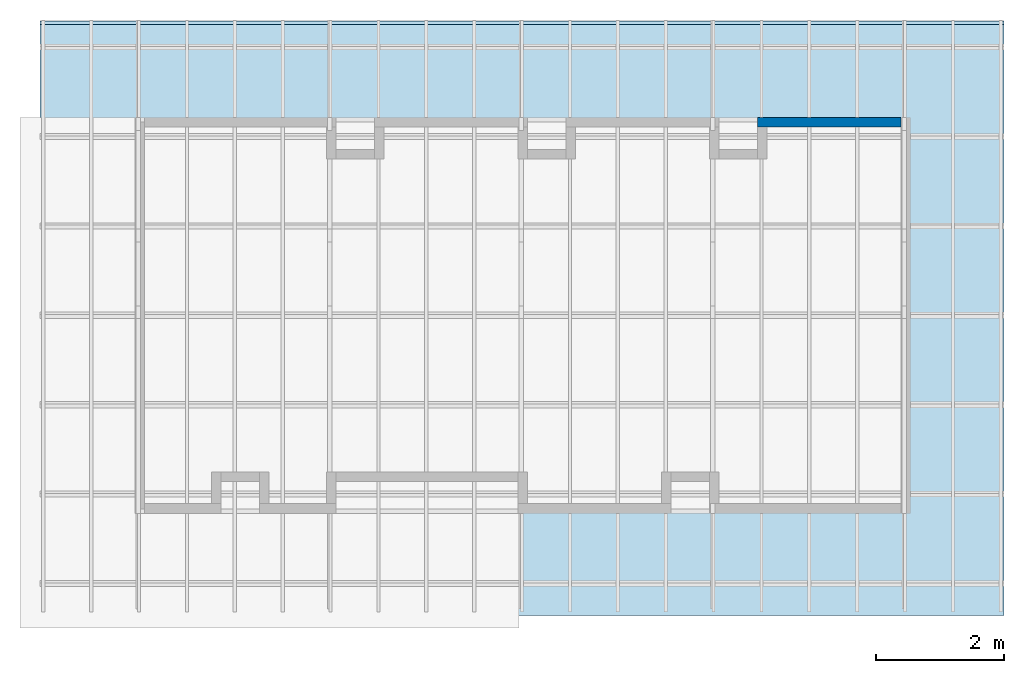
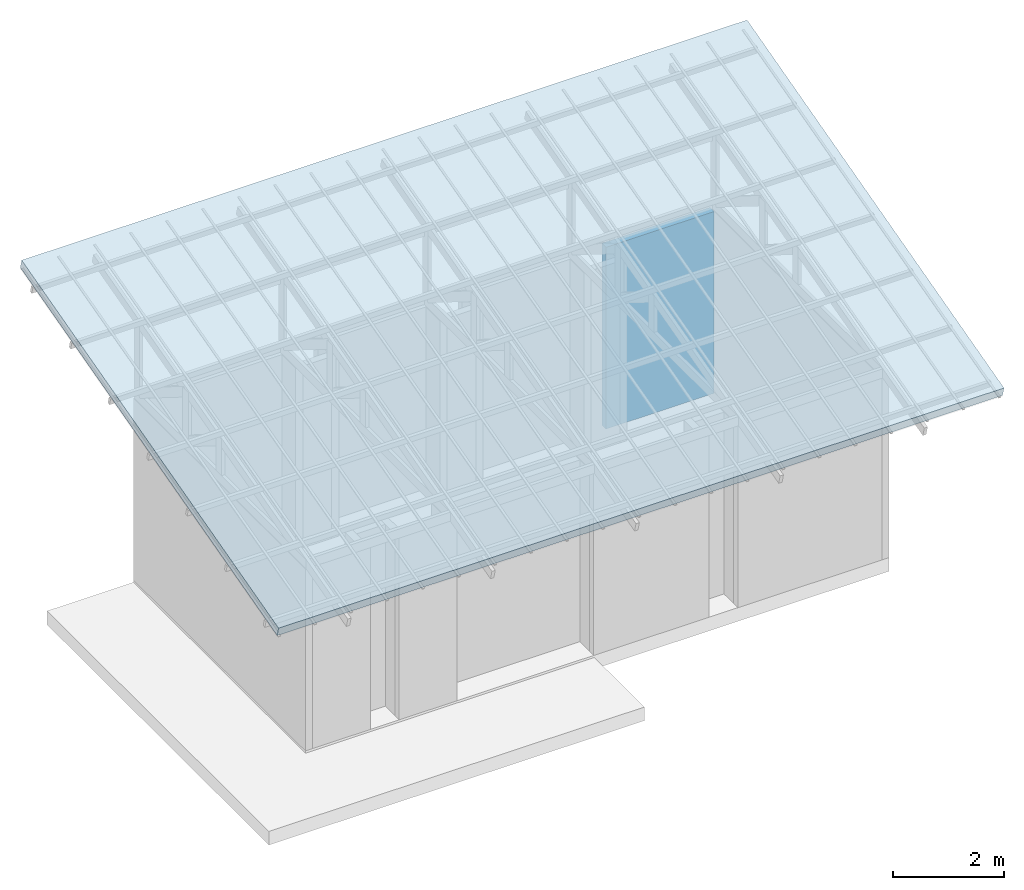
# One storey, part 3 of 4: 1 roof, 1 wall.
"""IFC4 building model written with IfcOpenShell, lengths in metres."""

from ifc_helpers import new_model, entity, si_unit, converted_unit, frame, origin_with_axes, origin_2d_with_axis, place, context, subcontext, project, spatial, indexed_curve, outline, extrude, polygons, material, layer, layer_set, layer_usage, type_object, element, save


model = new_model("IFC4")

# Units and contexts
model_context = context("Model", 3, precision=1e-05, world=origin_with_axes())
plan_context = context("Plan", 2, precision=1e-05, world=origin_2d_with_axis())
body_context = subcontext(model_context, "Body", "Model", "MODEL_VIEW")
ifc_project = project(units=[si_unit("VOLUMEUNIT", "CUBIC_METRE"), si_unit("LENGTHUNIT", "METRE"), converted_unit("PLANEANGLEUNIT", "degree", entity("IfcReal", 0.0174532925199433), si_unit("PLANEANGLEUNIT", "RADIAN"), dimensions=[0, 0, 0, 0, 0, 0, 0]), si_unit("AREAUNIT", "SQUARE_METRE")], contexts=[model_context, plan_context])

# Site, building, storey
site_placement = place(None, origin_with_axes())
site = spatial("IfcSite", under=ifc_project, at=site_placement)
building_placement = place(site_placement, origin_with_axes())
building = spatial("IfcBuilding", under=site, at=building_placement, Name="Building")
storey_placement = place(building_placement, origin_with_axes())
storey = spatial("IfcBuildingStorey", under=building, at=storey_placement, Name="Storey")

# Wall
ifc_material_1 = material(Name="Material")
ifc_layer = layer(ifc_material_1, 0.150000005960464)
ifc_layer_set = layer_set([ifc_layer])
ifc_layer_usage = layer_usage(ifc_layer_set, "AXIS2", "POSITIVE", 0.0)
wall_type = type_object("IfcWallType", Name="WAL150", PredefinedType="SOLIDWALL", material=ifc_layer_set)
wall_placement = place(storey_placement, frame((9.75000190734864, 6.0499963760376, 0.0), z_axis=(0.0, 0.0, 1.0), x_axis=(1.0, -5.96046447753906e-07, 0.0)))
element("IfcWall", 1, at=wall_placement, inside=storey, type_object=wall_type, material=ifc_layer_usage, Name="Wall", PredefinedType="NOTDEFINED", context=body_context, shape_type="SweptSolid", body=[
    extrude(outline(indexed_curve([(0.0, 0.0), (0.0, 0.150000005960464), (2.25000000000045, 0.150000005960464), (2.25000000000045, 0.0), (0.0, 0.0)], self_intersect=False)), origin_with_axes(), (0.0, 0.0, 1.0), 4.0),
])

# Roof
ifc_material_2 = material(Name="brick")
roof_placement = place(storey_placement, frame((12.6150007247925, -0.585902571678162, 4.25711727142334), z_axis=(5.74696369890976e-17, -0.258820205926895, 0.965925514698029), x_axis=(1.0, 7.56604983663575e-18, -5.74696369890976e-17)))
element("IfcRoof", 2, at=roof_placement, inside=storey, material=ifc_material_2, Name="Plane", PredefinedType="HIP_ROOF", context=body_context, shape_type="Tessellation", body=[
    polygons([(-14.100001335144, -1.0, 0.0), (1.0, -1.0, 0.0), (-14.100001335144, 8.5898904800415, 0.0), (1.0, 8.5898904800415, 0.0), (-14.100001335144, 8.5898904800415, 0.200000002980232), (-14.100001335144, -1.0, 0.200000002980232), (1.0, -1.0, 0.200000002980232), (1.0, 8.5898904800415, 0.200000002980232)], [[[1, 3, 4, 2]], [[6, 7, 8, 5]], [[4, 3, 5, 8]], [[1, 2, 7, 6]], [[2, 4, 8, 7]], [[3, 1, 6, 5]]]),
])

save(model, "model.ifc")
